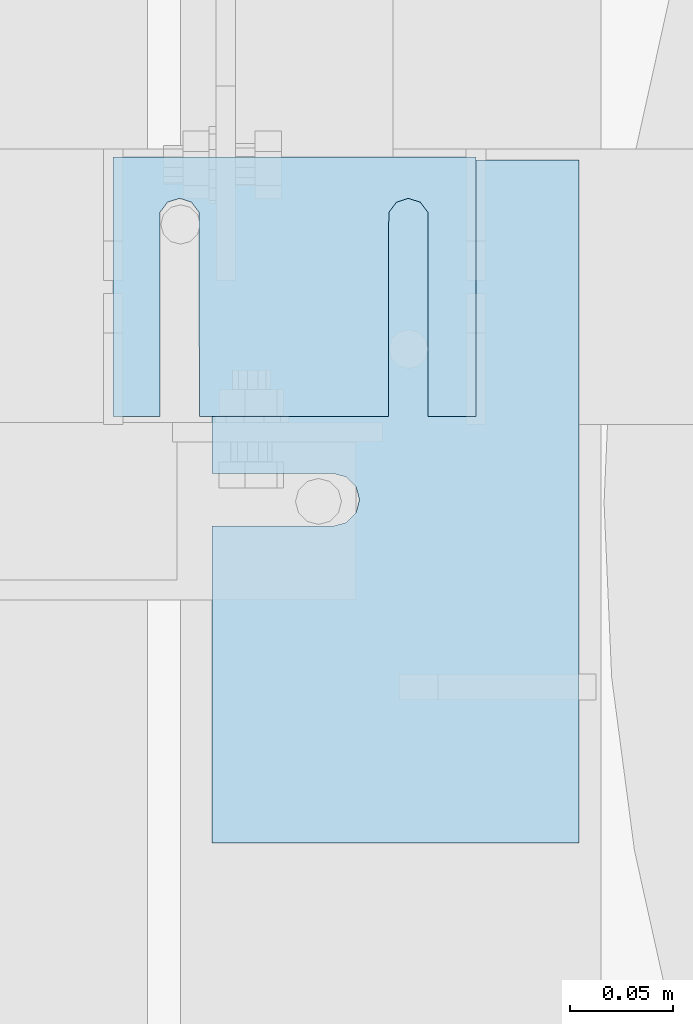
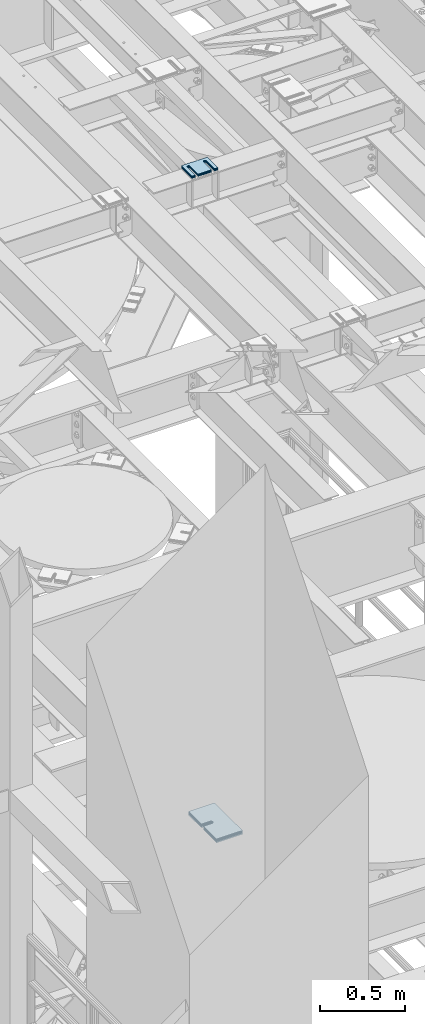
# One storey, part 1629 of 1876: 11 plates, 11 elements without a shape of their own.
"""IFC2X3 building model written with IfcOpenShell, lengths in millimetres."""

from ifc_helpers import new_model, si_unit, frame, origin_with_axes, place, context, subcontext, project, spatial, faceted_brep, material, type_object, element, aggregate, save


model = new_model("IFC2X3")

# Units and contexts
model_context = context("Model", 3, precision=1e-05, world=origin_with_axes())
body_context = subcontext(model_context, "Body", "Model", "MODEL_VIEW")
ifc_project = project(units=[si_unit("LENGTHUNIT", "METRE", prefix="MILLI"), si_unit("AREAUNIT", "SQUARE_METRE"), si_unit("VOLUMEUNIT", "CUBIC_METRE"), si_unit("MASSUNIT", "GRAM", prefix="KILO"), si_unit("TIMEUNIT", "SECOND"), si_unit("PLANEANGLEUNIT", "RADIAN"), si_unit("SOLIDANGLEUNIT", "STERADIAN"), si_unit("THERMODYNAMICTEMPERATUREUNIT", "DEGREE_CELSIUS"), si_unit("LUMINOUSINTENSITYUNIT", "LUMEN")], contexts=[model_context])

# Site, building, storey
site_placement = place(None, origin_with_axes())
site = spatial("IfcSite", under=ifc_project, at=site_placement, CompositionType="ELEMENT")
building_placement = place(site_placement, origin_with_axes())
building = spatial("IfcBuilding", under=site, at=building_placement, Name="Undefined", CompositionType="ELEMENT")
storey_placement = place(building_placement, origin_with_axes())
storey = spatial("IfcBuildingStorey", under=building, at=storey_placement, Name="Undefined", CompositionType="ELEMENT", Elevation=0.0)

# Assembly, plate
assembly_1_placement = place(storey_placement, origin_with_axes())
assembly_1 = element("IfcElementAssembly", 1, at=assembly_1_placement, inside=storey, Name="SHIM PLATE", AssemblyPlace="NOTDEFINED", PredefinedType="RIGID_FRAME")
ifc_material = material(Name="STEEL/A36")
plate_type_1 = type_object("IfcPlateType", PredefinedType="NOTDEFINED")
plate_1_placement = place(assembly_1_placement, frame((2343.14900265253, 5342.49779911307, 18009.3925), z_axis=(0.0, -1.0, 0.0), x_axis=(-1.0, 0.0, 0.0)))
plate_1 = element("IfcPlate", 2, at=plate_1_placement, type_object=plate_type_1, material=ifc_material, Name="SHIM PLATE", context=body_context, shape_type="Brep", body=[
    faceted_brep([(133.797984932592, -0.793499999999767, 125.39846801759), (133.799788185712, -0.793499999999767, 32.6385373098888), (133.799788185712, 0.793499999999767, 32.6385373098888), (133.797984932592, 0.793499999999767, 125.39846801759), (133.95251601168, -0.793499999999767, 26.6039999741197), (133.95251601168, 0.793499999999767, 26.6039999741197), (137.574395327988, -0.793499999999767, 21.7748223149583), (137.574395327988, 0.793499999999767, 21.7748223149583), (143.324785467194, -0.793499999999767, 19.9385271609622), (143.324785467194, 0.793499999999767, 19.9385271609622), (149.075176282759, -0.793499999999767, 21.7748201969102), (149.075176282759, 0.793499999999767, 21.7748201969102), (152.697057377795, -0.793499999999767, 26.6039965220207), (152.697057377795, 0.793499999999767, 26.6039965220207), (152.84978742646, -0.793499999999767, 32.6385338015343), (152.84978742646, 0.793499999999767, 32.6385338015343), (152.847984173361, -0.793499999999767, 125.398468017593), (152.847984173361, 0.793499999999767, 125.398468017593), (42.2236708188493, -0.793499999999767, 125.398468017582), (42.2236708188493, 0.793499999999767, 125.398468017582), (42.2254740719682, 0.793499999999767, 32.6385328059155), (42.2254740719682, -0.793499999999767, 32.6385328059155), (42.0727440233031, 0.793499999999767, 26.6039955264014), (42.0727440233031, -0.793499999999767, 26.6039955264014), (38.4508629282668, 0.793499999999767, 21.7748192012914), (38.4508629282668, -0.793499999999767, 21.7748192012914), (32.7004721127014, 0.793499999999767, 19.9385261653433), (32.7004721127014, -0.793499999999767, 19.9385261653433), (26.9500819734958, 0.793499999999767, 21.7748213193395), (26.9500819734958, -0.793499999999767, 21.7748213193395), (23.3282026571874, 0.793499999999767, 26.6039989785008), (23.3282026571874, -0.793499999999767, 26.6039989785008), (23.1754748312196, 0.793499999999767, 32.6385363142699), (23.1754748312196, -0.793499999999767, 32.6385363142699), (23.1736715780803, -0.793499999999767, 125.39846801758), (23.1736715780803, 0.793499999999767, 125.39846801758), (1.96488858819066e-05, 0.793499999999767, 125.398468017578), (1.96488858819066e-05, -0.793499999999767, 125.398468017578), (9.09494701772928e-13, -0.793499999999767, 0.0), (9.09494701772928e-13, 0.793499999999767, 0.0), (175.397720336914, -0.793499999999767, 7.27595761418343e-12), (175.397720336914, 0.793499999999767, 7.27595761418343e-12), (175.397735595691, -0.793499999999767, 125.398468017594), (175.397735595691, 0.793499999999767, 125.398468017594)], [[[0, 1, 2, 3]], [[4, 5, 2, 1]], [[6, 7, 5, 4]], [[8, 9, 7, 6]], [[10, 11, 9, 8]], [[12, 13, 11, 10]], [[14, 15, 13, 12]], [[16, 17, 15, 14]], [[18, 19, 20, 21]], [[21, 20, 22, 23]], [[23, 22, 24, 25]], [[25, 24, 26, 27]], [[27, 26, 28, 29]], [[29, 28, 30, 31]], [[31, 30, 32, 33]], [[34, 33, 32, 35]], [[36, 37, 34, 35]], [[38, 37, 36, 39]], [[40, 38, 39, 41]], [[42, 40, 41, 43]], [[12, 10, 8, 6, 4, 1, 0, 18, 21, 23, 25, 27, 29, 31, 33, 34, 37, 38, 40, 42, 16, 14]], [[19, 18, 0, 3]], [[43, 41, 39, 36, 35, 32, 30, 28, 26, 24, 22, 20, 19, 3, 2, 5, 7, 9, 11, 13, 15, 17]], [[42, 43, 17, 16]]]),
])
aggregate(assembly_1, [plate_1])

assembly_2_placement = place(storey_placement, origin_with_axes())
assembly_2 = element("IfcElementAssembly", 3, at=assembly_2_placement, inside=storey, Name="SHIM PLATE", AssemblyPlace="NOTDEFINED", PredefinedType="RIGID_FRAME")
plate_type_2 = type_object("IfcPlateType", PredefinedType="NOTDEFINED")
plate_2_placement = place(assembly_2_placement, frame((2343.14900265253, 5342.49779911314, 18007.0115), z_axis=(0.0, -1.0, 0.0), x_axis=(-1.0, 0.0, 0.0)))
plate_2 = element("IfcPlate", 4, at=plate_2_placement, type_object=plate_type_2, material=ifc_material, Name="SHIM PLATE", context=body_context, shape_type="Brep", body=[
    faceted_brep([(133.797984932592, -1.58750000000146, 125.39846801759), (133.799788185712, -1.58750000000146, 32.6385373098888), (133.799788185712, 1.58750000000146, 32.6385373098888), (133.797984932592, 1.58750000000146, 125.39846801759), (133.95251601168, -1.58750000000146, 26.6039999741197), (133.95251601168, 1.58750000000146, 26.6039999741197), (137.574395327988, -1.58750000000146, 21.7748223149583), (137.574395327988, 1.58750000000146, 21.7748223149583), (143.324785467194, -1.58750000000146, 19.9385271609622), (143.324785467194, 1.58750000000146, 19.9385271609622), (149.075176282759, -1.58750000000146, 21.7748201969102), (149.075176282759, 1.58750000000146, 21.7748201969102), (152.697057377795, -1.58750000000146, 26.6039965220207), (152.697057377795, 1.58750000000146, 26.6039965220207), (152.84978742646, -1.58750000000146, 32.6385338015343), (152.84978742646, 1.58750000000146, 32.6385338015343), (152.847984173361, -1.58750000000146, 125.398468017593), (152.847984173361, 1.58750000000146, 125.398468017593), (42.2236708188493, -1.58750000000146, 125.398468017582), (42.2236708188493, 1.58750000000146, 125.398468017582), (42.2254740719682, 1.58750000000146, 32.6385328059155), (42.2254740719682, -1.58750000000146, 32.6385328059155), (42.0727440233031, 1.58750000000146, 26.6039955264014), (42.0727440233031, -1.58750000000146, 26.6039955264014), (38.4508629282668, 1.58750000000146, 21.7748192012914), (38.4508629282668, -1.58750000000146, 21.7748192012914), (32.7004721127014, 1.58750000000146, 19.9385261653433), (32.7004721127014, -1.58750000000146, 19.9385261653433), (26.9500819734958, 1.58750000000146, 21.7748213193395), (26.9500819734958, -1.58750000000146, 21.7748213193395), (23.3282026571874, 1.58750000000146, 26.6039989785008), (23.3282026571874, -1.58750000000146, 26.6039989785008), (23.1754748312196, 1.58750000000146, 32.6385363142699), (23.1754748312196, -1.58750000000146, 32.6385363142699), (23.1736715780803, -1.58750000000146, 125.39846801758), (23.1736715780803, 1.58750000000146, 125.39846801758), (1.96491696442536e-05, 1.58750000000146, 125.398468017578), (1.96491696442536e-05, -1.58750000000146, 125.398468017578), (9.09494701772928e-13, -1.58750000000146, 4.54747350886464e-13), (9.09494701772928e-13, 1.58750000000146, 4.54747350886464e-13), (175.397720336914, -1.58750000000146, 7.27595761418343e-12), (175.397720336914, 1.58750000000146, 7.27595761418343e-12), (175.397735595691, -1.58750000000146, 125.398468017594), (175.397735595691, 1.58750000000146, 125.398468017594)], [[[0, 1, 2, 3]], [[4, 5, 2, 1]], [[6, 7, 5, 4]], [[8, 9, 7, 6]], [[10, 11, 9, 8]], [[12, 13, 11, 10]], [[14, 15, 13, 12]], [[16, 17, 15, 14]], [[18, 19, 20, 21]], [[21, 20, 22, 23]], [[23, 22, 24, 25]], [[25, 24, 26, 27]], [[27, 26, 28, 29]], [[29, 28, 30, 31]], [[31, 30, 32, 33]], [[34, 33, 32, 35]], [[36, 37, 34, 35]], [[38, 37, 36, 39]], [[40, 38, 39, 41]], [[42, 40, 41, 43]], [[12, 10, 8, 6, 4, 1, 0, 18, 21, 23, 25, 27, 29, 31, 33, 34, 37, 38, 40, 42, 16, 14]], [[19, 18, 0, 3]], [[43, 41, 39, 36, 35, 32, 30, 28, 26, 24, 22, 20, 19, 3, 2, 5, 7, 9, 11, 13, 15, 17]], [[42, 43, 17, 16]]]),
])
aggregate(assembly_2, [plate_2])

assembly_3_placement = place(storey_placement, origin_with_axes())
assembly_3 = element("IfcElementAssembly", 5, at=assembly_3_placement, inside=storey, Name="SHIM PLATE", AssemblyPlace="NOTDEFINED", PredefinedType="RIGID_FRAME")
plate_3_placement = place(assembly_3_placement, frame((2343.14900265253, 5342.49779911323, 18003.8365), z_axis=(0.0, -1.0, 0.0), x_axis=(-1.0, 0.0, 0.0)))
plate_3 = element("IfcPlate", 6, at=plate_3_placement, type_object=plate_type_2, material=ifc_material, Name="SHIM PLATE", context=body_context, shape_type="Brep", body=[
    faceted_brep([(133.797984932592, -1.58750000000146, 125.39846801759), (133.799788185712, -1.58750000000146, 32.6385373098888), (133.799788185712, 1.58750000000146, 32.6385373098888), (133.797984932592, 1.58750000000146, 125.39846801759), (133.95251601168, -1.58750000000146, 26.6039999741197), (133.95251601168, 1.58750000000146, 26.6039999741197), (137.574395327988, -1.58750000000146, 21.7748223149583), (137.574395327988, 1.58750000000146, 21.7748223149583), (143.324785467194, -1.58750000000146, 19.9385271609622), (143.324785467194, 1.58750000000146, 19.9385271609622), (149.075176282759, -1.58750000000146, 21.7748201969102), (149.075176282759, 1.58750000000146, 21.7748201969102), (152.697057377795, -1.58750000000146, 26.6039965220207), (152.697057377795, 1.58750000000146, 26.6039965220207), (152.84978742646, -1.58750000000146, 32.6385338015343), (152.84978742646, 1.58750000000146, 32.6385338015343), (152.847984173361, -1.58750000000146, 125.398468017593), (152.847984173361, 1.58750000000146, 125.398468017593), (42.2236708188493, -1.58750000000146, 125.398468017582), (42.2236708188493, 1.58750000000146, 125.398468017582), (42.2254740719682, 1.58750000000146, 32.6385328059155), (42.2254740719682, -1.58750000000146, 32.6385328059155), (42.0727440233031, 1.58750000000146, 26.6039955264014), (42.0727440233031, -1.58750000000146, 26.6039955264014), (38.4508629282668, 1.58750000000146, 21.7748192012914), (38.4508629282668, -1.58750000000146, 21.7748192012914), (32.7004721127014, 1.58750000000146, 19.9385261653433), (32.7004721127014, -1.58750000000146, 19.9385261653433), (26.9500819734958, 1.58750000000146, 21.7748213193395), (26.9500819734958, -1.58750000000146, 21.7748213193395), (23.3282026571874, 1.58750000000146, 26.6039989785008), (23.3282026571874, -1.58750000000146, 26.6039989785008), (23.1754748312196, 1.58750000000146, 32.6385363142699), (23.1754748312196, -1.58750000000146, 32.6385363142699), (23.1736715780803, -1.58750000000146, 125.39846801758), (23.1736715780803, 1.58750000000146, 125.39846801758), (1.96491696442536e-05, 1.58750000000146, 125.398468017578), (1.96491696442536e-05, -1.58750000000146, 125.398468017578), (9.09494701772928e-13, -1.58750000000146, 4.54747350886464e-13), (9.09494701772928e-13, 1.58750000000146, 4.54747350886464e-13), (175.397720336914, -1.58750000000146, 7.27595761418343e-12), (175.397720336914, 1.58750000000146, 7.27595761418343e-12), (175.397735595691, -1.58750000000146, 125.398468017594), (175.397735595691, 1.58750000000146, 125.398468017594)], [[[0, 1, 2, 3]], [[4, 5, 2, 1]], [[6, 7, 5, 4]], [[8, 9, 7, 6]], [[10, 11, 9, 8]], [[12, 13, 11, 10]], [[14, 15, 13, 12]], [[16, 17, 15, 14]], [[18, 19, 20, 21]], [[21, 20, 22, 23]], [[23, 22, 24, 25]], [[25, 24, 26, 27]], [[27, 26, 28, 29]], [[29, 28, 30, 31]], [[31, 30, 32, 33]], [[34, 33, 32, 35]], [[36, 37, 34, 35]], [[38, 37, 36, 39]], [[40, 38, 39, 41]], [[42, 40, 41, 43]], [[12, 10, 8, 6, 4, 1, 0, 18, 21, 23, 25, 27, 29, 31, 33, 34, 37, 38, 40, 42, 16, 14]], [[19, 18, 0, 3]], [[43, 41, 39, 36, 35, 32, 30, 28, 26, 24, 22, 20, 19, 3, 2, 5, 7, 9, 11, 13, 15, 17]], [[42, 43, 17, 16]]]),
])
aggregate(assembly_3, [plate_3])

assembly_4_placement = place(storey_placement, origin_with_axes())
assembly_4 = element("IfcElementAssembly", 7, at=assembly_4_placement, inside=storey, Name="SHIM PLATE", AssemblyPlace="NOTDEFINED", PredefinedType="RIGID_FRAME")
plate_type_3 = type_object("IfcPlateType", PredefinedType="NOTDEFINED")
plate_4_placement = place(assembly_4_placement, frame((2343.14900265253, 5342.49779911331, 17999.868), z_axis=(0.0, -1.0, 0.0), x_axis=(-1.0, 0.0, 0.0)))
plate_4 = element("IfcPlate", 8, at=plate_4_placement, type_object=plate_type_3, material=ifc_material, Name="SHIM PLATE", context=body_context, shape_type="Brep", body=[
    faceted_brep([(133.797984932592, -2.38100000000122, 125.39846801759), (133.799788185712, -2.38100000000122, 32.6385373098888), (133.799788185712, 2.38100000000122, 32.6385373098888), (133.797984932592, 2.38100000000122, 125.39846801759), (133.95251601168, -2.38100000000122, 26.6039999741197), (133.95251601168, 2.38100000000122, 26.6039999741197), (137.574395327988, -2.38100000000122, 21.7748223149583), (137.574395327988, 2.38100000000122, 21.7748223149583), (143.324785467194, -2.38100000000122, 19.9385271609622), (143.324785467194, 2.38100000000122, 19.9385271609622), (149.075176282759, -2.38100000000122, 21.7748201969102), (149.075176282759, 2.38100000000122, 21.7748201969102), (152.697057377795, -2.38100000000122, 26.6039965220207), (152.697057377795, 2.38100000000122, 26.6039965220207), (152.84978742646, -2.38100000000122, 32.6385338015343), (152.84978742646, 2.38100000000122, 32.6385338015343), (152.847984173361, -2.38100000000122, 125.398468017593), (152.847984173361, 2.38100000000122, 125.398468017593), (42.2236708188493, -2.38100000000122, 125.398468017582), (42.2236708188493, 2.38100000000122, 125.398468017582), (42.2254740719682, 2.38100000000122, 32.6385328059155), (42.2254740719682, -2.38100000000122, 32.6385328059155), (42.0727440233031, 2.38100000000122, 26.6039955264014), (42.0727440233031, -2.38100000000122, 26.6039955264014), (38.4508629282668, 2.38100000000122, 21.7748192012914), (38.4508629282668, -2.38100000000122, 21.7748192012914), (32.7004721127014, 2.38100000000122, 19.9385261653433), (32.7004721127014, -2.38100000000122, 19.9385261653433), (26.9500819734958, 2.38100000000122, 21.7748213193395), (26.9500819734958, -2.38100000000122, 21.7748213193395), (23.3282026571874, 2.38100000000122, 26.6039989785008), (23.3282026571874, -2.38100000000122, 26.6039989785008), (23.1754748312196, 2.38100000000122, 32.6385363142699), (23.1754748312196, -2.38100000000122, 32.6385363142699), (23.1736715780803, -2.38100000000122, 125.39846801758), (23.1736715780803, 2.38100000000122, 125.39846801758), (1.96494534066005e-05, 2.38100000000122, 125.398468017578), (1.96494534066005e-05, -2.38100000000122, 125.398468017578), (0.0, -2.38100000000122, 4.54747350886464e-13), (0.0, 2.38100000000122, 4.54747350886464e-13), (175.397720336914, -2.38100000000122, 7.27595761418343e-12), (175.397720336914, 2.38100000000122, 7.27595761418343e-12), (175.397735595691, -2.38100000000122, 125.398468017594), (175.397735595691, 2.38100000000122, 125.398468017594)], [[[0, 1, 2, 3]], [[4, 5, 2, 1]], [[6, 7, 5, 4]], [[8, 9, 7, 6]], [[10, 11, 9, 8]], [[12, 13, 11, 10]], [[14, 15, 13, 12]], [[16, 17, 15, 14]], [[18, 19, 20, 21]], [[21, 20, 22, 23]], [[23, 22, 24, 25]], [[25, 24, 26, 27]], [[27, 26, 28, 29]], [[29, 28, 30, 31]], [[31, 30, 32, 33]], [[34, 33, 32, 35]], [[36, 37, 34, 35]], [[38, 37, 36, 39]], [[40, 38, 39, 41]], [[42, 40, 41, 43]], [[12, 10, 8, 6, 4, 1, 0, 18, 21, 23, 25, 27, 29, 31, 33, 34, 37, 38, 40, 42, 16, 14]], [[19, 18, 0, 3]], [[43, 41, 39, 36, 35, 32, 30, 28, 26, 24, 22, 20, 19, 3, 2, 5, 7, 9, 11, 13, 15, 17]], [[42, 43, 17, 16]]]),
])
aggregate(assembly_4, [plate_4])

assembly_5_placement = place(storey_placement, origin_with_axes())
assembly_5 = element("IfcElementAssembly", 9, at=assembly_5_placement, inside=storey, Name="SHIM PLATE", AssemblyPlace="NOTDEFINED", PredefinedType="RIGID_FRAME")
plate_5_placement = place(assembly_5_placement, frame((2343.14900265253, 5342.49779911339, 17995.106), z_axis=(0.0, -1.0, 0.0), x_axis=(-1.0, 0.0, 0.0)))
plate_5 = element("IfcPlate", 10, at=plate_5_placement, type_object=plate_type_3, material=ifc_material, Name="SHIM PLATE", context=body_context, shape_type="Brep", body=[
    faceted_brep([(133.797984932592, -2.38100000000122, 125.39846801759), (133.799788185712, -2.38100000000122, 32.6385373098888), (133.799788185712, 2.38100000000122, 32.6385373098888), (133.797984932592, 2.38100000000122, 125.39846801759), (133.95251601168, -2.38100000000122, 26.6039999741197), (133.95251601168, 2.38100000000122, 26.6039999741197), (137.574395327988, -2.38100000000122, 21.7748223149583), (137.574395327988, 2.38100000000122, 21.7748223149583), (143.324785467194, -2.38100000000122, 19.9385271609622), (143.324785467194, 2.38100000000122, 19.9385271609622), (149.075176282759, -2.38100000000122, 21.7748201969102), (149.075176282759, 2.38100000000122, 21.7748201969102), (152.697057377795, -2.38100000000122, 26.6039965220207), (152.697057377795, 2.38100000000122, 26.6039965220207), (152.84978742646, -2.38100000000122, 32.6385338015343), (152.84978742646, 2.38100000000122, 32.6385338015343), (152.847984173361, -2.38100000000122, 125.398468017593), (152.847984173361, 2.38100000000122, 125.398468017593), (42.2236708188493, -2.38100000000122, 125.398468017582), (42.2236708188493, 2.38100000000122, 125.398468017582), (42.2254740719682, 2.38100000000122, 32.6385328059155), (42.2254740719682, -2.38100000000122, 32.6385328059155), (42.0727440233031, 2.38100000000122, 26.6039955264014), (42.0727440233031, -2.38100000000122, 26.6039955264014), (38.4508629282668, 2.38100000000122, 21.7748192012914), (38.4508629282668, -2.38100000000122, 21.7748192012914), (32.7004721127014, 2.38100000000122, 19.9385261653433), (32.7004721127014, -2.38100000000122, 19.9385261653433), (26.9500819734958, 2.38100000000122, 21.7748213193395), (26.9500819734958, -2.38100000000122, 21.7748213193395), (23.3282026571874, 2.38100000000122, 26.6039989785008), (23.3282026571874, -2.38100000000122, 26.6039989785008), (23.1754748312196, 2.38100000000122, 32.6385363142699), (23.1754748312196, -2.38100000000122, 32.6385363142699), (23.1736715780803, -2.38100000000122, 125.39846801758), (23.1736715780803, 2.38100000000122, 125.39846801758), (1.96494534066005e-05, 2.38100000000122, 125.398468017578), (1.96494534066005e-05, -2.38100000000122, 125.398468017578), (0.0, -2.38100000000122, 4.54747350886464e-13), (0.0, 2.38100000000122, 4.54747350886464e-13), (175.397720336914, -2.38100000000122, 7.27595761418343e-12), (175.397720336914, 2.38100000000122, 7.27595761418343e-12), (175.397735595691, -2.38100000000122, 125.398468017594), (175.397735595691, 2.38100000000122, 125.398468017594)], [[[0, 1, 2, 3]], [[4, 5, 2, 1]], [[6, 7, 5, 4]], [[8, 9, 7, 6]], [[10, 11, 9, 8]], [[12, 13, 11, 10]], [[14, 15, 13, 12]], [[16, 17, 15, 14]], [[18, 19, 20, 21]], [[21, 20, 22, 23]], [[23, 22, 24, 25]], [[25, 24, 26, 27]], [[27, 26, 28, 29]], [[29, 28, 30, 31]], [[31, 30, 32, 33]], [[34, 33, 32, 35]], [[36, 37, 34, 35]], [[38, 37, 36, 39]], [[40, 38, 39, 41]], [[42, 40, 41, 43]], [[12, 10, 8, 6, 4, 1, 0, 18, 21, 23, 25, 27, 29, 31, 33, 34, 37, 38, 40, 42, 16, 14]], [[19, 18, 0, 3]], [[43, 41, 39, 36, 35, 32, 30, 28, 26, 24, 22, 20, 19, 3, 2, 5, 7, 9, 11, 13, 15, 17]], [[42, 43, 17, 16]]]),
])
aggregate(assembly_5, [plate_5])

assembly_6_placement = place(storey_placement, origin_with_axes())
assembly_6 = element("IfcElementAssembly", 11, at=assembly_6_placement, inside=storey, Name="SHIM PLATE", AssemblyPlace="NOTDEFINED", PredefinedType="RIGID_FRAME")
plate_type_4 = type_object("IfcPlateType", PredefinedType="NOTDEFINED")
plate_6_placement = place(assembly_6_placement, frame((2393.05223303297, 5010.98586578369, 13335.7925), z_axis=(0.0, 1.0, 0.0), x_axis=(-1.0, 0.0, 0.0)))
plate_6 = element("IfcPlate", 12, at=plate_6_placement, type_object=plate_type_4, material=ifc_material, Name="SHIM PLATE", context=body_context, shape_type="Brep", body=[
    faceted_brep([(177.654449462891, -0.793499999999767, 153.152024232435), (177.654449462891, 0.793499999999767, 153.152024232435), (118.915740966797, 0.793499999999767, 153.152024232435), (118.915740966797, -0.793499999999767, 153.152024232435), (112.565739046814, 0.793499999999767, 154.853499989362), (112.565739046814, -0.793499999999767, 154.853499989362), (107.917214530273, 0.793499999999767, 159.502022760557), (107.917214530273, -0.793499999999767, 159.502022760557), (106.21573638916, 0.793499999999767, 165.8520240417), (106.21573638916, -0.793499999999767, 165.8520240417), (107.917214530273, 0.793499999999767, 172.202025322844), (107.917214530273, -0.793499999999767, 172.202025322844), (112.565739046813, 0.793499999999767, 176.850548094039), (112.565739046813, -0.793499999999767, 176.850548094039), (118.915740966797, 0.793499999999767, 178.552023850965), (118.915740966797, -0.793499999999767, 178.552023850965), (177.654449462891, -0.793499999999767, 178.552023850965), (177.654449462891, 0.793499999999767, 178.552023850965), (177.654449462891, -0.793499999999767, 0.0), (9.09494701772928e-13, -0.793499999999767, 0.0), (9.09494701772928e-13, 0.793499999999767, 0.0), (177.654449462891, 0.793499999999767, 0.0), (0.0, -0.793499999999767, 330.201965332031), (0.0, 0.793499999999767, 330.201965332031), (177.654449462891, -0.793499999999767, 330.201965332031), (177.654449462891, 0.793499999999767, 330.201965332031)], [[[0, 1, 2, 3]], [[3, 2, 4, 5]], [[5, 4, 6, 7]], [[7, 6, 8, 9]], [[9, 8, 10, 11]], [[11, 10, 12, 13]], [[13, 12, 14, 15]], [[16, 15, 14, 17]], [[18, 19, 20, 21]], [[19, 22, 23, 20]], [[22, 24, 25, 23]], [[25, 24, 16, 17]], [[12, 10, 8, 6, 4, 2, 1, 21, 20, 23, 25, 17, 14]], [[18, 21, 1, 0]], [[24, 22, 19, 18, 0, 3, 5, 7, 9, 11, 13, 15, 16]]]),
])
aggregate(assembly_6, [plate_6])

assembly_7_placement = place(storey_placement, origin_with_axes())
assembly_7 = element("IfcElementAssembly", 13, at=assembly_7_placement, inside=storey, Name="SHIM PLATE", AssemblyPlace="NOTDEFINED", PredefinedType="RIGID_FRAME")
plate_type_5 = type_object("IfcPlateType", PredefinedType="NOTDEFINED")
plate_7_placement = place(assembly_7_placement, frame((2393.05223303297, 5010.98586578369, 13333.4115), z_axis=(0.0, 1.0, 0.0), x_axis=(-1.0, 0.0, 0.0)))
plate_7 = element("IfcPlate", 14, at=plate_7_placement, type_object=plate_type_5, material=ifc_material, Name="SHIM PLATE", context=body_context, shape_type="Brep", body=[
    faceted_brep([(177.654449462891, -1.58749999999964, 153.152024232435), (177.654449462891, 1.58749999999964, 153.152024232435), (118.915740966797, 1.58749999999964, 153.152024232435), (118.915740966797, -1.58749999999964, 153.152024232435), (112.565739046814, 1.58749999999964, 154.853499989362), (112.565739046814, -1.58749999999964, 154.853499989362), (107.917214530273, 1.58749999999964, 159.502022760557), (107.917214530273, -1.58749999999964, 159.502022760557), (106.21573638916, 1.58749999999964, 165.8520240417), (106.21573638916, -1.58749999999964, 165.8520240417), (107.917214530273, 1.58749999999964, 172.202025322844), (107.917214530273, -1.58749999999964, 172.202025322844), (112.565739046813, 1.58749999999964, 176.850548094039), (112.565739046813, -1.58749999999964, 176.850548094039), (118.915740966797, 1.58749999999964, 178.552023850965), (118.915740966797, -1.58749999999964, 178.552023850965), (177.654449462891, -1.58749999999964, 178.552023850965), (177.654449462891, 1.58749999999964, 178.552023850965), (177.654449462891, -1.58749999999964, 0.0), (9.09494701772928e-13, -1.58750000000146, 4.54747350886464e-13), (9.09494701772928e-13, 1.58750000000146, 4.54747350886464e-13), (177.654449462891, 1.58749999999964, 0.0), (0.0, -1.58749999999964, 330.201965332031), (0.0, 1.58749999999964, 330.201965332031), (177.654449462891, -1.58749999999964, 330.201965332031), (177.654449462891, 1.58749999999964, 330.201965332031)], [[[0, 1, 2, 3]], [[3, 2, 4, 5]], [[5, 4, 6, 7]], [[7, 6, 8, 9]], [[9, 8, 10, 11]], [[11, 10, 12, 13]], [[13, 12, 14, 15]], [[16, 15, 14, 17]], [[18, 19, 20, 21]], [[19, 22, 23, 20]], [[22, 24, 25, 23]], [[25, 24, 16, 17]], [[12, 10, 8, 6, 4, 2, 1, 21, 20, 23, 25, 17, 14]], [[18, 21, 1, 0]], [[24, 22, 19, 18, 0, 3, 5, 7, 9, 11, 13, 15, 16]]]),
])
aggregate(assembly_7, [plate_7])

assembly_8_placement = place(storey_placement, origin_with_axes())
assembly_8 = element("IfcElementAssembly", 15, at=assembly_8_placement, inside=storey, Name="SHIM PLATE", AssemblyPlace="NOTDEFINED", PredefinedType="RIGID_FRAME")
plate_8_placement = place(assembly_8_placement, frame((2393.05223303297, 5010.98586578369, 13330.2365), z_axis=(0.0, 1.0, 0.0), x_axis=(-1.0, 0.0, 0.0)))
plate_8 = element("IfcPlate", 16, at=plate_8_placement, type_object=plate_type_5, material=ifc_material, Name="SHIM PLATE", context=body_context, shape_type="Brep", body=[
    faceted_brep([(177.654449462891, -1.58749999999964, 153.152024232435), (177.654449462891, 1.58749999999964, 153.152024232435), (118.915740966797, 1.58749999999964, 153.152024232435), (118.915740966797, -1.58749999999964, 153.152024232435), (112.565739046814, 1.58749999999964, 154.853499989362), (112.565739046814, -1.58749999999964, 154.853499989362), (107.917214530273, 1.58749999999964, 159.502022760557), (107.917214530273, -1.58749999999964, 159.502022760557), (106.21573638916, 1.58749999999964, 165.8520240417), (106.21573638916, -1.58749999999964, 165.8520240417), (107.917214530273, 1.58749999999964, 172.202025322844), (107.917214530273, -1.58749999999964, 172.202025322844), (112.565739046813, 1.58749999999964, 176.850548094039), (112.565739046813, -1.58749999999964, 176.850548094039), (118.915740966797, 1.58749999999964, 178.552023850965), (118.915740966797, -1.58749999999964, 178.552023850965), (177.654449462891, -1.58749999999964, 178.552023850965), (177.654449462891, 1.58749999999964, 178.552023850965), (177.654449462891, -1.58749999999964, 0.0), (9.09494701772928e-13, -1.58750000000146, 4.54747350886464e-13), (9.09494701772928e-13, 1.58750000000146, 4.54747350886464e-13), (177.654449462891, 1.58749999999964, 0.0), (0.0, -1.58749999999964, 330.201965332031), (0.0, 1.58749999999964, 330.201965332031), (177.654449462891, -1.58749999999964, 330.201965332031), (177.654449462891, 1.58749999999964, 330.201965332031)], [[[0, 1, 2, 3]], [[3, 2, 4, 5]], [[5, 4, 6, 7]], [[7, 6, 8, 9]], [[9, 8, 10, 11]], [[11, 10, 12, 13]], [[13, 12, 14, 15]], [[16, 15, 14, 17]], [[18, 19, 20, 21]], [[19, 22, 23, 20]], [[22, 24, 25, 23]], [[25, 24, 16, 17]], [[12, 10, 8, 6, 4, 2, 1, 21, 20, 23, 25, 17, 14]], [[18, 21, 1, 0]], [[24, 22, 19, 18, 0, 3, 5, 7, 9, 11, 13, 15, 16]]]),
])
aggregate(assembly_8, [plate_8])

assembly_9_placement = place(storey_placement, origin_with_axes())
assembly_9 = element("IfcElementAssembly", 17, at=assembly_9_placement, inside=storey, Name="SHIM PLATE", AssemblyPlace="NOTDEFINED", PredefinedType="RIGID_FRAME")
plate_type_6 = type_object("IfcPlateType", PredefinedType="NOTDEFINED")
plate_9_placement = place(assembly_9_placement, frame((2393.05223303297, 5010.98586578369, 13326.268), z_axis=(0.0, 1.0, 0.0), x_axis=(-1.0, 0.0, 0.0)))
plate_9 = element("IfcPlate", 18, at=plate_9_placement, type_object=plate_type_6, material=ifc_material, Name="SHIM PLATE", context=body_context, shape_type="Brep", body=[
    faceted_brep([(177.654449462891, -2.3809999999994, 153.152024232435), (177.654449462891, 2.3809999999994, 153.152024232435), (118.915740966797, 2.3809999999994, 153.152024232435), (118.915740966797, -2.3809999999994, 153.152024232435), (112.565739046814, 2.3809999999994, 154.853499989362), (112.565739046814, -2.3809999999994, 154.853499989362), (107.917214530273, 2.3809999999994, 159.502022760557), (107.917214530273, -2.3809999999994, 159.502022760557), (106.21573638916, 2.3809999999994, 165.8520240417), (106.21573638916, -2.3809999999994, 165.8520240417), (107.917214530273, 2.3809999999994, 172.202025322844), (107.917214530273, -2.3809999999994, 172.202025322844), (112.565739046813, 2.3809999999994, 176.850548094039), (112.565739046813, -2.3809999999994, 176.850548094039), (118.915740966797, 2.3809999999994, 178.552023850965), (118.915740966797, -2.3809999999994, 178.552023850965), (177.654449462891, -2.3809999999994, 178.552023850965), (177.654449462891, 2.3809999999994, 178.552023850965), (177.654449462891, -2.3809999999994, 0.0), (0.0, -2.38100000000122, 4.54747350886464e-13), (0.0, 2.38100000000122, 4.54747350886464e-13), (177.654449462891, 2.3809999999994, 0.0), (0.0, -2.3809999999994, 330.201965332031), (0.0, 2.3809999999994, 330.201965332031), (177.654449462891, -2.3809999999994, 330.201965332031), (177.654449462891, 2.3809999999994, 330.201965332031)], [[[0, 1, 2, 3]], [[3, 2, 4, 5]], [[5, 4, 6, 7]], [[7, 6, 8, 9]], [[9, 8, 10, 11]], [[11, 10, 12, 13]], [[13, 12, 14, 15]], [[16, 15, 14, 17]], [[18, 19, 20, 21]], [[19, 22, 23, 20]], [[22, 24, 25, 23]], [[25, 24, 16, 17]], [[12, 10, 8, 6, 4, 2, 1, 21, 20, 23, 25, 17, 14]], [[18, 21, 1, 0]], [[24, 22, 19, 18, 0, 3, 5, 7, 9, 11, 13, 15, 16]]]),
])
aggregate(assembly_9, [plate_9])

assembly_10_placement = place(storey_placement, origin_with_axes())
assembly_10 = element("IfcElementAssembly", 19, at=assembly_10_placement, inside=storey, Name="SHIM PLATE", AssemblyPlace="NOTDEFINED", PredefinedType="RIGID_FRAME")
plate_10_placement = place(assembly_10_placement, frame((2393.05223303297, 5010.98586578369, 13321.506), z_axis=(0.0, 1.0, 0.0), x_axis=(-1.0, 0.0, 0.0)))
plate_10 = element("IfcPlate", 20, at=plate_10_placement, type_object=plate_type_6, material=ifc_material, Name="SHIM PLATE", context=body_context, shape_type="Brep", body=[
    faceted_brep([(177.654449462891, -2.3809999999994, 153.152024232435), (177.654449462891, 2.3809999999994, 153.152024232435), (118.915740966797, 2.3809999999994, 153.152024232435), (118.915740966797, -2.3809999999994, 153.152024232435), (112.565739046814, 2.3809999999994, 154.853499989362), (112.565739046814, -2.3809999999994, 154.853499989362), (107.917214530273, 2.3809999999994, 159.502022760557), (107.917214530273, -2.3809999999994, 159.502022760557), (106.21573638916, 2.3809999999994, 165.8520240417), (106.21573638916, -2.3809999999994, 165.8520240417), (107.917214530273, 2.3809999999994, 172.202025322844), (107.917214530273, -2.3809999999994, 172.202025322844), (112.565739046813, 2.3809999999994, 176.850548094039), (112.565739046813, -2.3809999999994, 176.850548094039), (118.915740966797, 2.3809999999994, 178.552023850965), (118.915740966797, -2.3809999999994, 178.552023850965), (177.654449462891, -2.3809999999994, 178.552023850965), (177.654449462891, 2.3809999999994, 178.552023850965), (177.654449462891, -2.3809999999994, 0.0), (0.0, -2.38100000000122, 4.54747350886464e-13), (0.0, 2.38100000000122, 4.54747350886464e-13), (177.654449462891, 2.3809999999994, 0.0), (0.0, -2.3809999999994, 330.201965332031), (0.0, 2.3809999999994, 330.201965332031), (177.654449462891, -2.3809999999994, 330.201965332031), (177.654449462891, 2.3809999999994, 330.201965332031)], [[[0, 1, 2, 3]], [[3, 2, 4, 5]], [[5, 4, 6, 7]], [[7, 6, 8, 9]], [[9, 8, 10, 11]], [[11, 10, 12, 13]], [[13, 12, 14, 15]], [[16, 15, 14, 17]], [[18, 19, 20, 21]], [[19, 22, 23, 20]], [[22, 24, 25, 23]], [[25, 24, 16, 17]], [[12, 10, 8, 6, 4, 2, 1, 21, 20, 23, 25, 17, 14]], [[18, 21, 1, 0]], [[24, 22, 19, 18, 0, 3, 5, 7, 9, 11, 13, 15, 16]]]),
])
aggregate(assembly_10, [plate_10])

assembly_11_placement = place(storey_placement, origin_with_axes())
assembly_11 = element("IfcElementAssembly", 21, at=assembly_11_placement, inside=storey, Name="SHIM PLATE", AssemblyPlace="NOTDEFINED", PredefinedType="RIGID_FRAME")
plate_type_7 = type_object("IfcPlateType", PredefinedType="NOTDEFINED")
plate_11_placement = place(assembly_11_placement, frame((2393.05223303297, 5010.98586578369, 13314.3625), z_axis=(0.0, 1.0, 0.0), x_axis=(-1.0, 0.0, 0.0)))
plate_11 = element("IfcPlate", 22, at=plate_11_placement, type_object=plate_type_7, material=ifc_material, Name="SHIM PLATE", context=body_context, shape_type="Brep", body=[
    faceted_brep([(177.654449462891, -4.76250000000073, 153.152024232435), (177.654449462891, 4.76250000000073, 153.152024232435), (118.915740966797, 4.76250000000073, 153.152024232435), (118.915740966797, -4.76250000000073, 153.152024232435), (112.565739046814, 4.76250000000073, 154.853499989362), (112.565739046814, -4.76250000000073, 154.853499989362), (107.917214530273, 4.76250000000073, 159.502022760557), (107.917214530273, -4.76250000000073, 159.502022760557), (106.21573638916, 4.76250000000073, 165.8520240417), (106.21573638916, -4.76250000000073, 165.8520240417), (107.917214530273, 4.76250000000073, 172.202025322844), (107.917214530273, -4.76250000000073, 172.202025322844), (112.565739046813, 4.76250000000073, 176.850548094039), (112.565739046813, -4.76250000000073, 176.850548094039), (118.915740966797, 4.76250000000073, 178.552023850965), (118.915740966797, -4.76250000000073, 178.552023850965), (177.654449462891, -4.76250000000073, 178.552023850965), (177.654449462891, 4.76250000000073, 178.552023850965), (177.654449462891, -4.76250000000073, 0.0), (0.0, -4.76249999999982, 0.0), (0.0, 4.76249999999982, 0.0), (177.654449462891, 4.76250000000073, 0.0), (0.0, -4.76250000000073, 330.201965332031), (0.0, 4.76250000000073, 330.201965332031), (177.654449462891, -4.76250000000073, 330.201965332031), (177.654449462891, 4.76250000000073, 330.201965332031)], [[[0, 1, 2, 3]], [[3, 2, 4, 5]], [[5, 4, 6, 7]], [[7, 6, 8, 9]], [[9, 8, 10, 11]], [[11, 10, 12, 13]], [[13, 12, 14, 15]], [[16, 15, 14, 17]], [[18, 19, 20, 21]], [[19, 22, 23, 20]], [[22, 24, 25, 23]], [[25, 24, 16, 17]], [[12, 10, 8, 6, 4, 2, 1, 21, 20, 23, 25, 17, 14]], [[18, 21, 1, 0]], [[24, 22, 19, 18, 0, 3, 5, 7, 9, 11, 13, 15, 16]]]),
])
aggregate(assembly_11, [plate_11])

save(model, "model.ifc")
